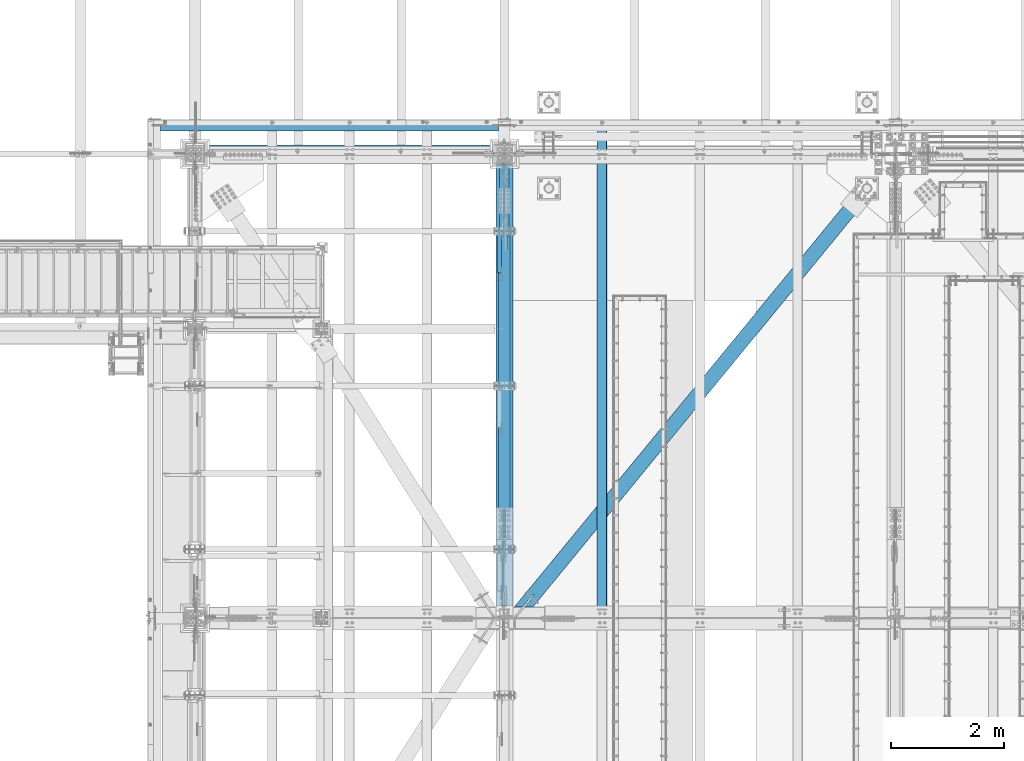
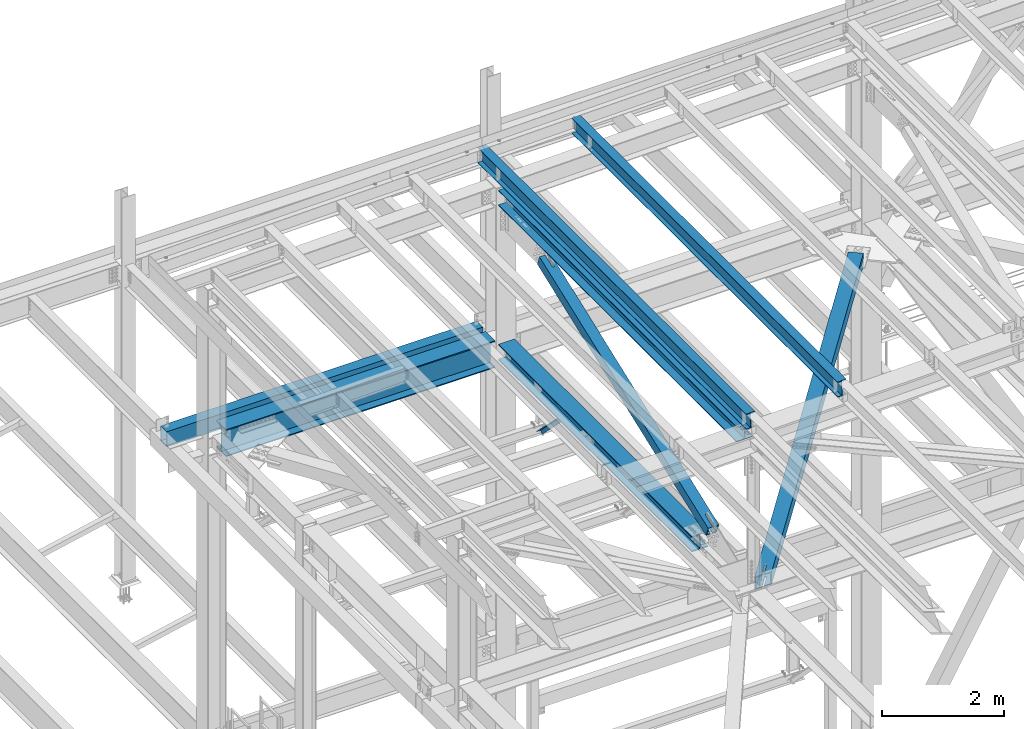
# One storey, part 1888 of 3843: 7 beams, 2 members, 9 elements without a shape of their own.
"""IFC2X3 building model written with IfcOpenShell, lengths in millimetres."""

from ifc_helpers import new_model, si_unit, frame, origin_with_axes, place, context, subcontext, project, spatial, faceted_brep, material, type_object, element, aggregate, save


model = new_model("IFC2X3")

# Units and contexts
model_context = context("Model", 3, precision=1e-05, world=origin_with_axes())
body_context = subcontext(model_context, "Body", "Model", "MODEL_VIEW")
ifc_project = project(units=[si_unit("LENGTHUNIT", "METRE", prefix="MILLI"), si_unit("AREAUNIT", "SQUARE_METRE"), si_unit("VOLUMEUNIT", "CUBIC_METRE"), si_unit("MASSUNIT", "GRAM", prefix="KILO"), si_unit("TIMEUNIT", "SECOND"), si_unit("PLANEANGLEUNIT", "RADIAN"), si_unit("SOLIDANGLEUNIT", "STERADIAN"), si_unit("THERMODYNAMICTEMPERATUREUNIT", "DEGREE_CELSIUS"), si_unit("LUMINOUSINTENSITYUNIT", "LUMEN")], contexts=[model_context])

# Site, building, storey
site_placement = place(None, origin_with_axes())
site = spatial("IfcSite", under=ifc_project, at=site_placement, CompositionType="ELEMENT")
building_placement = place(site_placement, origin_with_axes())
building = spatial("IfcBuilding", under=site, at=building_placement, Name="Undefined", CompositionType="ELEMENT")
storey_placement = place(building_placement, origin_with_axes())
storey = spatial("IfcBuildingStorey", under=building, at=storey_placement, Name="Undefined", CompositionType="ELEMENT", Elevation=0.0)

# Assembly, beam
assembly_1_placement = place(storey_placement, origin_with_axes())
assembly_1 = element("IfcElementAssembly", 1, at=assembly_1_placement, inside=storey, Name="BEAM", AssemblyPlace="NOTDEFINED", PredefinedType="RIGID_FRAME")
ifc_material_1 = material(Name="STEEL/A992")
beam_type_1 = type_object("IfcBeamType", Name="W12X26", PredefinedType="NOTDEFINED")
beam_1_placement = place(assembly_1_placement, frame((43792.6592623349, 83985.1612976655, 45730.1499365069), z_axis=(-0.0211520976501051, 0.00039400699987891, 0.999776191716668), x_axis=(0.0, 0.999999922344562, -0.000394095000135883)))
beam_1 = element("IfcBeam", 2, at=beam_1_placement, type_object=beam_type_1, material=ifc_material_1, Name="BEAM", ObjectType="W12X26", context=body_context, shape_type="Brep", body=[
    faceted_brep([(8748.71387345975, -3.17500000048312, -146.049999975585), (8748.71387345977, -82.5500000003376, -146.049999975723), (8748.71387345986, -82.5500000003449, -155.574999975746), (8748.71387345986, 82.5499999993408, -155.574999975448), (8748.71387345977, 82.5499999993335, -146.049999975425), (8748.71387345977, 3.17499999948632, -146.04999997557), (8748.71387346018, 3.17499999949359, -142.874999321568), (8748.71387346015, -3.17500000049768, -142.874999321597), (8749.68060338277, 3.17499999949359, -138.014919803456), (8749.68060338275, -3.17500000049768, -138.014919803478), (8752.4336172833, 3.17499999949359, -133.89474333523), (8752.43361728328, -3.17500000050495, -133.894743335251), (8756.55379375159, 3.17499999949359, -131.141729434697), (8756.55379375156, -3.17500000050495, -131.141729434727), (8761.41387326975, 3.17499999949359, -130.174999512106), (8761.41387326973, -3.17500000050495, -130.174999512128), (8818.55315012705, -3.17500000049768, -130.174999512412), (8818.55320306026, 3.17499999949359, -130.174999512412), (12.5811850809841, 3.17499999997381, 146.050000000287), (12.5818467461504, 82.549999999821, 146.050000000425), (8748.71387345965, 82.5499999992971, 146.050000025061), (8748.71387345964, 3.17499999944994, 146.050000024916), (12.699343723325, -82.5500000003594, -155.575000000019), (12.6955598859931, -82.549999999821, -146.050000000367), (12.6961738177852, -3.17499999995925, -146.05000000049), (12.5811321477668, -3.17500000001019, 146.050000000272), (12.5804704826005, -82.5499999998574, 146.050000000127), (12.5767175672809, -82.5499999998501, 155.575000000143), (12.5780938308308, 82.549999999821, 155.575000000448), (12.6962744843622, 3.17500000001019, -146.050000000199), (12.6968955877383, 82.5499999998865, -146.050000000643), (12.700657964604, 82.5499999993335, -155.575000000419), (8748.71387345965, -3.17500000052678, 146.050000024901), (8748.71387345965, -82.550000000374, 146.050000024756), (8748.7138734597, -82.550000000374, 155.575000024772), (8748.7138734597, 82.5499999992971, 155.57500002507), (8748.71387345999, -3.17500000053406, 142.875000297521), (8748.71387346002, 3.17499999945721, 142.875000297543), (8749.68060338256, -3.17500000053406, 138.014920779446), (8749.68060338259, 3.17499999944994, 138.014920779468), (8752.43361728308, -3.17500000053406, 133.894744311248), (8752.4336172831, 3.17499999945721, 133.894744311285), (8756.55379375129, -3.17500000052678, 131.141730410745), (8756.55379375131, 3.17499999945721, 131.141730410774), (8761.41387326943, -3.17500000052678, 130.175000488147), (8761.41387326944, 3.17499999945721, 130.175000488161), (8818.45057044142, -3.17500000052678, 130.175000487565), (8818.45062337464, 3.17499999944994, 130.175000487558), (8818.54648030871, 3.17499999947904, -113.112475336362), (8818.45562233418, 3.17499999944994, 117.487506764461)], [[[0, 1, 2, 3, 4, 5, 6, 7]], [[7, 6, 8, 9]], [[9, 8, 10, 11]], [[11, 10, 12, 13]], [[13, 12, 14, 15]], [[16, 15, 14, 17]], [[18, 19, 20, 21]], [[22, 23, 24, 25, 26, 27, 28, 19, 18, 29, 30, 31]], [[26, 25, 32, 33]], [[27, 26, 33, 34]], [[28, 27, 34, 35]], [[19, 28, 35, 20]], [[34, 33, 32, 36, 37, 21, 20, 35]], [[38, 39, 37, 36]], [[40, 41, 39, 38]], [[42, 43, 41, 40]], [[44, 45, 43, 42]], [[46, 47, 45, 44]], [[48, 49, 47, 46, 16, 17]], [[12, 10, 8, 6, 5, 29, 18, 21, 37, 39, 41, 43, 45, 47, 49, 48, 17, 14]], [[30, 29, 5, 4]], [[31, 30, 4, 3]], [[22, 31, 3, 2]], [[23, 22, 2, 1]], [[24, 23, 1, 0]], [[46, 44, 42, 40, 38, 36, 32, 25, 24, 0, 7, 9, 11, 13, 15, 16]]]),
])
aggregate(assembly_1, [beam_1])

assembly_2_placement = place(storey_placement, origin_with_axes())
assembly_2 = element("IfcElementAssembly", 3, at=assembly_2_placement, inside=storey, Name="BEAM", AssemblyPlace="NOTDEFINED", PredefinedType="RIGID_FRAME")
beam_2_placement = place(assembly_2_placement, frame((42059.1092623669, 83985.1465797427, 45692.6371083062), z_axis=(-0.0211520979557754, 0.000299403999859351, 0.999776224516924), x_axis=(0.0, 0.999999955158559, -0.000299471000047185)))
beam_2 = element("IfcBeam", 4, at=beam_2_placement, type_object=beam_type_1, material=ifc_material_1, Name="BEAM", ObjectType="W12X26", context=body_context, shape_type="Brep", body=[
    faceted_brep([(12.7004890030294, 82.5499999993262, -155.574999999742), (12.6976716898789, 82.5500000003158, -146.050000000272), (8839.20039647813, 82.5500000005268, -146.050000010408), (8839.20039647816, 82.5500000005632, -155.575000010431), (12.6971688932244, 3.17500000047585, -146.050000000323), (8839.20039647768, 3.17500000068685, -146.050000010466), (12.6097129801346, 3.17499999950087, 146.050000000309), (8839.200396477, 3.17499999971187, 146.049999990166), (12.6102157767891, 82.5499999993408, 146.050000000359), (8839.20039647748, 82.5499999995591, 146.049999990209), (12.6073639535316, 82.5499999993117, 155.575000000375), (8839.20039647745, 82.5499999995227, 155.574999990233), (12.606318136488, -82.5500000003449, 155.575000000281), (8839.20039647649, -82.5500000001339, 155.574999990138), (12.6091699597309, -82.5500000003231, 146.050000000265), (8839.20039647652, -82.5500000001048, 146.049999990115), (12.6096727563854, -3.17500000048312, 146.050000000309), (8839.20039647697, -3.17500000027212, 146.049999990159), (12.6971286695043, -3.17499999950815, -146.050000000323), (8839.20039647765, -3.17499999929714, -146.050000010466), (12.6966258728353, -82.5499999993481, -146.050000000367), (8839.20039647717, -82.5499999991371, -146.050000010517), (12.6995121410655, -82.5500000004104, -155.574999999495), (8839.2003964772, -82.549999999108, -155.575000010533)], [[[0, 1, 2, 3]], [[1, 4, 5, 2]], [[4, 6, 7, 5]], [[6, 8, 9, 7]], [[8, 10, 11, 9]], [[10, 12, 13, 11]], [[12, 14, 15, 13]], [[14, 16, 17, 15]], [[16, 18, 19, 17]], [[18, 20, 21, 19]], [[20, 22, 23, 21]], [[22, 0, 3, 23]], [[5, 7, 9, 11, 13, 15, 17, 19, 21, 23, 3, 2]], [[22, 20, 18, 16, 14, 12, 10, 8, 6, 4, 1, 0]]]),
])
aggregate(assembly_2, [beam_2])

assembly_3_placement = place(storey_placement, origin_with_axes())
assembly_3 = element("IfcElementAssembly", 5, at=assembly_3_placement, inside=storey, Name="BEAM", AssemblyPlace="NOTDEFINED", PredefinedType="RIGID_FRAME")
beam_type_2 = type_object("IfcBeamType", Name="W21X101", PredefinedType="NOTDEFINED")
beam_3_placement = place(assembly_3_placement, frame((36576.0, 92214.7, 42197.3375), z_axis=(0.0, 0.0, 1.0), x_axis=(1.0, 0.0, 0.0)))
beam_3 = element("IfcBeam", 6, at=beam_3_placement, type_object=beam_type_2, material=ifc_material_1, Name="BEAM", ObjectType="W21X101", context=body_context, shape_type="Brep", body=[
    faceted_brep([(190.5, -155.575000000001, -271.462500000001), (190.5, 155.575000000001, -271.462500000001), (5289.55, 155.575000000001, -271.462500000001), (5289.55, -155.575000000001, -271.462500000001), (190.5, -155.575000000001, -250.824999999997), (190.5, -6.34999999999854, -250.824999999997), (190.5, -6.34999999999854, 250.824999999997), (190.5, -155.575000000001, 250.824999999997), (190.5, -155.575000000001, 271.462500000001), (190.5, 155.575000000001, 271.462500000001), (190.5, 155.575000000001, 250.824999999997), (190.5, 6.34999999999854, 250.824999999997), (190.5, 6.34999999999854, -250.824999999997), (190.5, 155.575000000001, -250.824999999997), (5289.55, -155.575000000001, -250.824999999997), (5289.55, -6.34999999999854, -250.824999999997), (5289.55, -6.34999999999854, 250.824999999997), (5289.55, -155.575000000001, 250.824999999997), (5289.55, -155.575000000001, 271.462500000001), (5289.55, 155.575000000001, 271.462500000001), (5289.55, 155.575000000001, 250.824999999997), (5289.55, 6.34999999999854, 250.824999999997), (5289.55, 6.34999999999854, -250.824999999997), (5289.55, 155.575000000001, -250.824999999997)], [[[0, 1, 2, 3]], [[0, 4, 5, 6, 7, 8, 9, 10, 11, 12, 13, 1]], [[5, 4, 14, 15]], [[6, 5, 15, 16]], [[7, 6, 16, 17]], [[8, 7, 17, 18]], [[9, 8, 18, 19]], [[10, 9, 19, 20]], [[11, 10, 20, 21]], [[12, 11, 21, 22]], [[13, 12, 22, 23]], [[1, 13, 23, 2]], [[22, 21, 20, 19, 18, 17, 16, 15, 14, 3, 2, 23]], [[4, 0, 3, 14]]]),
])
aggregate(assembly_3, [beam_3])

assembly_4_placement = place(storey_placement, origin_with_axes())
assembly_4 = element("IfcElementAssembly", 7, at=assembly_4_placement, inside=storey, Name="GIRT", AssemblyPlace="NOTDEFINED", PredefinedType="RIGID_FRAME")
ifc_material_2 = material()
beam_type_3 = type_object("IfcBeamType", Name="HSS12X8X3/8", PredefinedType="NOTDEFINED")
beam_4_placement = place(assembly_4_placement, frame((35963.225, 92722.7, 42214.8), z_axis=(0.0, 0.0, 1.0), x_axis=(1.0, 0.0, 0.0)))
beam_4 = element("IfcBeam", 8, at=beam_4_placement, type_object=beam_type_3, material=ifc_material_2, Name="GIRT", ObjectType="HSS12X8X3/8", context=body_context, shape_type="Brep", body=[
    faceted_brep([(5995.9875, 101.599999999999, -152.400000000001), (5995.9875, -101.599999999999, -152.400000000001), (1.58750000000146, -101.599999999999, -152.400000000001), (1.58750000000146, 101.599999999999, -152.400000000001), (5995.9875, 101.599999999999, 152.400000000001), (1.58750000000146, 101.599999999999, 152.400000000001), (5995.9875, -101.599999999999, 152.400000000001), (1.58750000000146, -101.599999999999, 152.400000000001), (5995.9875, 92.0750000000007, -142.875), (5995.9875, -92.0750000000007, -142.875), (5995.9875, -92.0750000000007, 142.875), (5995.9875, 92.0750000000007, 142.875), (1.58750000000146, -92.0750000000007, 142.875), (1.58750000000146, 92.0750000000007, 142.875), (1.58750000000146, 92.0750000000007, -142.875), (1.58750000000146, -92.0750000000007, -142.875)], [[[0, 1, 2, 3]], [[4, 0, 3, 5]], [[6, 4, 5, 7]], [[1, 6, 7, 2]], [[0, 4, 6, 1], [8, 9, 10, 11]], [[11, 10, 12, 13]], [[8, 11, 13, 14]], [[9, 8, 14, 15]], [[10, 9, 15, 12]], [[3, 2, 7, 5], [14, 13, 12, 15]]]),
])
aggregate(assembly_4, [beam_4])

# Assembly, member
assembly_5_placement = place(storey_placement, origin_with_axes())
assembly_5 = element("IfcElementAssembly", 9, at=assembly_5_placement, inside=storey, Name="ANGLE", AssemblyPlace="NOTDEFINED", PredefinedType="RIGID_FRAME")
ifc_material_3 = material(Name="STEEL/A572-50")
member_type_1 = type_object("IfcMemberType", Name="L3X3X1/4", PredefinedType="NOTDEFINED")
member_1_placement = place(assembly_5_placement, frame((41973.5, 89889.8478294408, 42253.6521705007), z_axis=(0.0, -0.707106781186548, -0.707106781186548), x_axis=(5.70000238222118e-08, 0.707106781186546, -0.707106781186546)))
member_1 = element("IfcMember", 10, at=member_1_placement, type_object=member_type_1, material=ifc_material_3, Name="ANGLE", ObjectType="L3X3X1/4", context=body_context, shape_type="Brep", body=[
    faceted_brep([(1265.10086725769, -38.0999999999985, -31.7499999999272), (1265.10086725772, -38.0999999999985, -38.0999999999112), (1265.10086725772, 38.0999999999985, -38.0999999999112), (1265.10086725733, 38.0999999999985, 38.099999999904), (1265.10086725733, 31.75, 38.099999999904), (1265.10086725769, 31.75, -31.7499999999272), (274.500867262255, 31.75, 38.0999999999112), (274.500867262619, 31.75, -31.7499999999272), (274.500867262619, -38.0999999999985, -31.7499999999272), (274.500867262648, -38.0999999999985, -38.0999999999112), (274.500867262648, 38.0999999999985, -38.0999999999112), (274.500867262255, 38.0999999999985, 38.0999999999112)], [[[0, 1, 2, 3, 4, 5]], [[5, 4, 6, 7]], [[0, 5, 7, 8]], [[1, 0, 8, 9]], [[2, 1, 9, 10]], [[3, 2, 10, 11]], [[4, 3, 11, 6]], [[10, 9, 8, 7, 6, 11]]]),
])
aggregate(assembly_5, [member_1])

# Assembly, beam
assembly_6_placement = place(storey_placement, origin_with_axes())
assembly_6 = element("IfcElementAssembly", 11, at=assembly_6_placement, inside=storey, Name="BEAM", AssemblyPlace="NOTDEFINED", PredefinedType="RIGID_FRAME")
beam_type_4 = type_object("IfcBeamType", Name="W12X79", PredefinedType="NOTDEFINED")
beam_5_placement = place(assembly_6_placement, frame((42062.4, 85661.5000000582, 42248.6579913964), z_axis=(0.0, 0.000321673000085866, 0.999999948263239), x_axis=(0.0, 0.999999948263239, -0.000321673000078448)))
beam_5 = element("IfcBeam", 12, at=beam_5_placement, type_object=beam_type_4, material=ifc_material_1, Name="BEAM", ObjectType="W12X79", context=body_context, shape_type="Brep", body=[
    faceted_brep([(6.34999999578577, -153.987500000003, -138.11249999961), (6.34999999578577, -153.987500000003, -157.162499999562), (6362.75088412264, -153.987500000003, -157.16249997681), (6362.74475625168, -153.987500000003, -138.112499976858), (6.34999999578577, -6.34999999999854, -138.11249999961), (6362.74475625168, -6.34999999999854, -138.112499976858), (6.34999999578577, -6.34999999999854, 138.112499999675), (6362.65590212263, -6.34999999999854, 138.112500022427), (6.34999999578577, -153.987500000003, 138.112499999675), (6362.65590212263, -153.987500000003, 138.112500022427), (6.34999999578577, -153.987500000003, 157.162499999627), (6362.64977425167, -153.987500000003, 157.162500022379), (6.34999999578577, 153.987500000003, 157.162499999627), (6362.64977425167, 153.987500000003, 157.162500022379), (6.34999999578577, 153.987500000003, 138.112499999675), (6362.65590212263, 153.987500000003, 138.112500022427), (6.34999999578577, 6.34999999999854, 138.112499999675), (6362.65590212263, 6.34999999999854, 138.112500022427), (6.34999999578577, 6.34999999999854, -138.11249999961), (6362.74475625168, 6.34999999999854, -138.112499976858), (6.34999999578577, 153.987500000003, -138.11249999961), (6362.74475625168, 153.987500000003, -138.112499976858), (6.34999999578577, 153.987500000003, -157.162499999562), (6362.75088412264, 153.987500000003, -157.16249997681)], [[[0, 1, 2, 3]], [[4, 0, 3, 5]], [[6, 4, 5, 7]], [[8, 6, 7, 9]], [[10, 8, 9, 11]], [[12, 10, 11, 13]], [[14, 12, 13, 15]], [[16, 14, 15, 17]], [[18, 16, 17, 19]], [[20, 18, 19, 21]], [[1, 0, 4, 6, 8, 10, 12, 14, 16, 18, 20, 22]], [[1, 22, 23, 2]], [[19, 17, 15, 13, 11, 9, 7, 5, 3, 2, 23, 21]], [[22, 20, 21, 23]]]),
])
aggregate(assembly_6, [beam_5])

# Assembly, member
assembly_7_placement = place(storey_placement, origin_with_axes())
assembly_7 = element("IfcElementAssembly", 13, at=assembly_7_placement, inside=storey, AssemblyPlace="NOTDEFINED", PredefinedType="RIGID_FRAME")
member_type_2 = type_object("IfcMemberType", Name="HSS8X8X1/2", PredefinedType="NOTDEFINED")
member_2_placement = place(assembly_7_placement, frame((42062.4, 83985.1, 42249.1989165104), z_axis=(1.0, 0.0, 0.0), x_axis=(0.0, 0.936145725867102, 0.351612257950085)))
member_2 = element("IfcMember", 14, at=member_2_placement, type_object=member_type_2, material=ifc_material_2, ObjectType="HSS8X8X1/2", context=body_context, shape_type="Brep", body=[
    faceted_brep([(1357.61058050461, -101.599999994112, 17.4625000000015), (1357.6105805047, -88.8999999941625, 17.4625000000015), (1610.0230808741, -88.8999999931548, 17.4625000000015), (1610.02308087397, -101.599999993097, 17.4625000000015), (1616.70569016575, -88.8999999931293, 16.1332463655199), (1616.70569016565, -101.599999993075, 16.1332463655199), (1622.37093277075, -88.8999999931075, 12.3478522782025), (1622.37093277063, -101.599999993046, 12.3478522782025), (1626.15632685805, -88.8999999930966, 6.68260967316746), (1626.15632685793, -101.599999993032, 6.68260967316746), (1610.02308087397, -101.599999993097, -17.4625000000015), (1610.0230808741, -88.8999999931548, -17.4625000000015), (1357.6105805047, -88.8999999941625, -17.4625000000015), (1357.61058050461, -101.599999994112, -17.4625000000015), (1616.70569016565, -101.599999993075, -16.1332463655199), (1616.70569016575, -88.8999999931293, -16.1332463655199), (1622.37093277063, -101.599999993046, -12.3478522782025), (1622.37093277075, -88.8999999931075, -12.3478522782025), (1626.15632685793, -101.599999993032, -6.68260967316746), (1626.15632685805, -88.8999999930966, -6.68260967316746), (1627.4855804924, -101.599999993021, 3.81471181754023e-07), (1627.48558049253, -88.8999999930893, 3.81471181754023e-07), (1357.61058050592, 88.900000005011, 17.4625000000015), (1357.61058050599, 101.600000004953, 17.4625000000015), (1610.02308087594, 101.600000005961, 17.4625000000015), (1610.02308087582, 88.9000000060223, 17.4625000000015), (1616.7056901676, 101.60000000599, 16.1332463655199), (1616.70569016747, 88.9000000060478, 16.1332463655199), (1622.37093277258, 101.600000006012, 12.3478522782025), (1622.37093277246, 88.9000000060732, 12.3478522782025), (1626.15632685987, 101.600000006027, 6.68260967316746), (1626.15632685977, 88.9000000060805, 6.68260967316746), (1610.02308087582, 88.9000000060223, -17.4625000000015), (1610.02308087594, 101.600000005961, -17.4625000000015), (1357.61058050599, 101.600000004953, -17.4625000000015), (1357.61058050592, 88.900000005011, -17.4625000000015), (1616.70569016747, 88.9000000060478, -16.1332463655199), (1616.7056901676, 101.60000000599, -16.1332463655199), (1622.37093277246, 88.9000000060732, -12.3478522782025), (1622.37093277258, 101.600000006012, -12.3478522782025), (1626.15632685977, 88.9000000060805, -6.68260967316746), (1626.15632685987, 101.600000006027, -6.68260967316746), (1627.48558049423, 88.9000000060878, 3.81471181754023e-07), (1627.48558049437, 101.600000006038, 3.81471181754023e-07), (1357.6105805047, -88.8999999941625, 88.9000000000015), (1357.61058050592, 88.900000005011, 88.9000000000015), (7279.42376524339, 88.9000000286615, 88.9000000000015), (7279.42376524217, -88.8999999705084, 88.9000000000015), (1357.61058050599, 101.600000004953, 101.599999999999), (7279.42376524347, 101.600000028611, 101.599999999999), (7279.42376524347, 101.600000028611, 41.2750000000015), (7027.01126488511, 101.6000000276, 41.2750000000015), (7020.32865559346, 101.600000027571, 39.9457463655199), (7014.66341298845, 101.600000027545, 36.1603522782025), (7010.87801890117, 101.600000027531, 30.4951096731675), (7009.54876526671, 101.600000027527, 23.8125003814712), (7010.87801890117, 101.600000027531, 17.1298903268325), (7014.66341298845, 101.600000027545, 11.4646477217975), (7020.32865559346, 101.600000027571, 7.67925363448012), (7027.01126488511, 101.6000000276, 6.34999999999854), (7279.42376524347, 101.600000028611, 6.34999999999854), (7279.42376524347, 101.600000028611, -101.599999999999), (1357.61058050599, 101.600000004953, -101.599999999999), (7279.42376524339, 88.9000000286615, 41.2750000000015), (7027.01126488499, 88.9000000276537, 41.2750000000015), (7020.32865559334, 88.9000000276246, 39.9457463655199), (7014.66341298835, 88.9000000276064, 36.1603522782025), (7010.87801890104, 88.9000000275919, 30.4951096731675), (7009.54876526658, 88.9000000275882, 23.8125003814712), (7010.87801890104, 88.9000000275919, 17.1298903268325), (7014.66341298835, 88.9000000276064, 11.4646477217975), (7020.32865559334, 88.9000000276246, 7.67925363448012), (7027.01126488499, 88.9000000276537, 6.34999999999854), (7279.42376524339, 88.9000000286615, 6.34999999999854), (1357.61058050592, 88.900000005011, -88.9000000000015), (1357.6105805047, -88.8999999941625, -88.9000000000015), (7279.42376524217, -88.8999999705084, -88.9000000000015), (7279.42376524339, 88.9000000286615, -88.9000000000015), (7020.32865559151, -101.59999997148, 39.9457463655199), (7020.32865559163, -88.8999999715488, 39.9457463655199), (7027.01126488329, -88.8999999715161, 41.2750000000015), (7027.01126488316, -101.599999971459, 41.2750000000015), (7014.66341298651, -101.599999971506, 36.1603522782025), (7014.66341298663, -88.899999971567, 36.1603522782025), (7010.87801889921, -101.599999971535, 30.4951096731675), (7010.87801889933, -88.8999999715816, 30.4951096731675), (7009.54876526474, -101.599999971528, 23.8125003814712), (7009.54876526486, -88.8999999715925, 23.8125003814712), (7010.87801889921, -101.599999971535, 17.1298903268325), (7010.87801889933, -88.8999999715816, 17.1298903268325), (7014.66341298651, -101.599999971506, 11.4646477217975), (7014.66341298663, -88.899999971567, 11.4646477217975), (7020.32865559151, -101.59999997148, 7.67925363448012), (7020.32865559163, -88.8999999715488, 7.67925363448012), (7027.01126488316, -101.599999971459, 6.34999999999854), (7027.01126488329, -88.8999999715161, 6.34999999999854), (7279.42376524209, -101.599999970455, 6.34999999999854), (7279.42376524217, -88.8999999705084, 6.34999999999854), (7279.42376524209, -101.599999970455, -101.599999999999), (1357.61058050461, -101.599999994112, -101.599999999999), (7279.42376524217, -88.8999999705084, 41.2750000000015), (7279.42376524209, -101.599999970455, 41.2750000000015), (7279.42376524209, -101.599999970455, 101.599999999999), (1357.61058050461, -101.599999994112, 101.599999999999)], [[[0, 1, 2, 3]], [[3, 2, 4, 5]], [[5, 4, 6, 7]], [[7, 6, 8, 9]], [[10, 11, 12, 13]], [[14, 15, 11, 10]], [[16, 17, 15, 14]], [[18, 19, 17, 16]], [[20, 21, 19, 18]], [[9, 8, 21, 20]], [[22, 23, 24, 25]], [[25, 24, 26, 27]], [[27, 26, 28, 29]], [[29, 28, 30, 31]], [[32, 33, 34, 35]], [[36, 37, 33, 32]], [[38, 39, 37, 36]], [[40, 41, 39, 38]], [[42, 43, 41, 40]], [[31, 30, 43, 42]], [[44, 45, 46, 47]], [[28, 26, 24, 23, 48, 49, 50, 51, 52, 53, 54, 55, 56, 57, 58, 59, 60, 61, 62, 34, 33, 37, 39, 41, 43, 30]], [[63, 64, 51, 50]], [[65, 52, 51, 64]], [[66, 53, 52, 65]], [[67, 54, 53, 66]], [[68, 55, 54, 67]], [[69, 56, 55, 68]], [[70, 57, 56, 69]], [[71, 58, 57, 70]], [[72, 59, 58, 71]], [[73, 60, 59, 72]], [[74, 75, 76, 77]], [[78, 79, 80, 81]], [[82, 83, 79, 78]], [[84, 85, 83, 82]], [[86, 87, 85, 84]], [[88, 89, 87, 86]], [[90, 91, 89, 88]], [[92, 93, 91, 90]], [[94, 95, 93, 92]], [[96, 97, 95, 94]], [[98, 61, 60, 73, 77, 76, 97, 96]], [[99, 62, 61, 98]], [[75, 74, 35, 34, 62, 99, 13, 12]], [[6, 4, 2, 1, 44, 47, 100, 80, 79, 83, 85, 87, 89, 91, 93, 95, 97, 76, 75, 12, 11, 15, 17, 19, 21, 8]], [[101, 81, 80, 100]], [[47, 46, 63, 50, 49, 102, 101, 100]], [[48, 103, 102, 49]], [[16, 14, 10, 13, 99, 98, 96, 94, 92, 90, 88, 86, 84, 82, 78, 81, 101, 102, 103, 0, 3, 5, 7, 9, 20, 18]], [[103, 48, 23, 22, 45, 44, 1, 0]], [[38, 36, 32, 35, 74, 77, 73, 72, 71, 70, 69, 68, 67, 66, 65, 64, 63, 46, 45, 22, 25, 27, 29, 31, 42, 40]]]),
])
aggregate(assembly_7, [member_2])

# Assembly, beam
assembly_8_placement = place(storey_placement, origin_with_axes())
assembly_8 = element("IfcElementAssembly", 15, at=assembly_8_placement, inside=storey, AssemblyPlace="NOTDEFINED", PredefinedType="RIGID_FRAME")
beam_type_5 = type_object("IfcBeamType", Name="HSS10X10X3/4", PredefinedType="NOTDEFINED")
beam_6_placement = place(assembly_8_placement, frame((42240.2, 83985.1, 42246.55), z_axis=(0.772893373971288, -0.634535918976442, 0.0), x_axis=(0.634535918976437, 0.772893373971293, 0.0)))
beam_6 = element("IfcBeam", 16, at=beam_6_placement, type_object=beam_type_5, material=ifc_material_2, ObjectType="HSS10X10X3/4", context=body_context, shape_type="Brep", body=[
    faceted_brep([(9595.05957983305, 26.9874999999956, 127.000000028405), (9342.64708020692, 26.9874999999956, 127.000000027656), (9342.64708020676, 26.9874999999956, 107.950000027704), (9595.05957983293, 26.9874999999956, 107.950000028461), (9337.179490521, 25.8999287917104, 127.000000027634), (9337.17949052084, 25.8999287917104, 107.950000027689), (9332.54429180092, 22.8027880244699, 127.00000002762), (9332.54429180076, 22.8027880244699, 107.950000027682), (9329.44715103366, 18.167589304423, 127.00000002762), (9329.44715103351, 18.167589304423, 107.950000027668), (9328.35957982538, 12.6999996185259, 127.000000027605), (9328.35957982522, 12.6999996185259, 107.950000027668), (9329.44715103366, 7.23241069557116, 127.00000002762), (9329.44715103351, 7.23241069557116, 107.950000027668), (9332.54429180092, 2.59721197552426, 127.00000002762), (9332.54429180076, 2.59721197552426, 107.950000027682), (9337.179490521, -0.499928791716229, 127.000000027634), (9337.17949052084, -0.499928791716229, 107.950000027689), (9342.64708020692, -1.58750000000146, 127.000000027656), (9342.64708020676, -1.58750000000146, 107.950000027704), (9595.05957983305, -1.58750000000146, 127.000000028405), (9595.05957983293, -1.58750000000146, 107.950000028461), (9595.05957983171, 26.9874999999956, -107.949999970944), (9342.647080205, 26.9874999999956, -107.949999971708), (9342.64708020483, 26.9874999999956, -126.99999997166), (9595.05957983161, 26.9874999999956, -126.999999970911), (9337.17949051905, 25.8999287917104, -107.949999971723), (9337.1794905189, 25.8999287917104, -126.999999971675), (9332.54429179899, 22.8027880244699, -107.949999971745), (9332.54429179883, 22.8027880244699, -126.999999971689), (9329.44715103172, 18.167589304423, -107.949999971752), (9329.44715103156, 18.167589304423, -126.999999971689), (9328.35957982343, 12.6999996185259, -107.949999971759), (9328.35957982329, 12.6999996185259, -126.999999971711), (9329.44715103172, 7.23241069557116, -107.949999971752), (9329.44715103156, 7.23241069557116, -126.999999971689), (9332.54429179899, 2.59721197552426, -107.949999971745), (9332.54429179883, 2.59721197552426, -126.999999971689), (9337.17949051905, -0.499928791716229, -107.949999971723), (9337.1794905189, -0.499928791716229, -126.999999971675), (9342.647080205, -1.58750000000146, -107.949999971708), (9342.64708020483, -1.58750000000146, -126.99999997166), (9595.05957983171, -1.58750000000146, -107.949999970944), (9595.05957983161, -1.58750000000146, -126.999999970911), (520.888642611997, 107.949999999997, 14.2875006717732), (520.888642611997, 127.0, 14.2875006717732), (526.35623229884, 127.0, 13.1999294678753), (526.35623229884, 107.949999999997, 13.1999294678753), (530.991431021416, 127.0, 10.1027887042655), (530.991431021416, 107.949999999997, 10.1027887042655), (534.088571792345, 127.0, 5.46758998659789), (534.088571792345, 107.949999999997, 5.46758998659789), (535.176143004898, 127.0, 1.06545485323295e-06), (535.176143004898, 107.949999999997, 1.06545485323295e-06), (534.088571800913, 127.0, -5.46758862111892), (534.088571800913, 107.949999999997, -5.46758862111892), (530.991431037416, 127.0, -10.1027873434723), (530.991431037416, 107.949999999997, -10.1027873434723), (526.356232319988, 127.0, -13.1999281143289), (526.356232319988, 107.949999999997, -13.1999281143289), (520.888642635131, 127.0, -14.287499326987), (520.888642635131, 107.949999999997, -14.287499326987), (245.016420763346, 127.0, -14.2874995510356), (245.016420763346, 107.949999999997, -14.2874995510356), (9595.05957915825, 107.949999999997, -107.950000001394), (168.12066424172, 107.949999999997, -107.949999999568), (168.12066424172, -107.949999999997, -107.949999999568), (9595.05957915825, -107.949999999997, -107.950000001394), (9595.05957915825, -107.949999999997, 107.949999997647), (245.016420763346, -107.949999999997, -14.2874995510356), (520.888642635131, -107.949999999997, -14.287499326987), (526.356232319988, -107.949999999997, -13.1999281143289), (530.991431037416, -107.949999999997, -10.1027873434723), (534.088571800913, -107.949999999997, -5.46758862111892), (535.176143004898, -107.949999999997, 1.06545485323295e-06), (534.088571792345, -107.949999999997, 5.46758998659789), (530.991431021416, -107.949999999997, 10.1027887042655), (526.35623229884, -107.949999999997, 13.1999294678753), (520.888642611997, -107.949999999997, 14.2875006717732), (268.476142995274, -107.949999999997, 14.2875004680172), (345.371898763963, -107.949999999997, 107.949999999437), (345.371898763963, 107.949999999997, 107.949999999437), (9595.05957915825, 107.949999999997, 107.949999997647), (268.476142995274, 107.949999999997, 14.2875004680172), (268.476142995274, 127.0, 14.2875004680172), (9595.05957915825, 127.0, 126.999999997548), (9595.05957915825, 127.0, -127.000000001302), (152.480849430937, 127.0, -126.999999999469), (361.011713574746, 127.0, 126.999999999352), (9595.05957915825, -127.0, -127.000000001302), (152.480849430937, -127.0, -126.999999999469), (245.016420763346, -127.0, -14.2874995510356), (520.888642635131, -127.0, -14.287499326987), (526.356232319988, -127.0, -13.1999281143289), (530.991431037416, -127.0, -10.1027873434723), (534.088571800913, -127.0, -5.46758862111892), (535.176143004898, -127.0, 1.06545485323295e-06), (534.088571792345, -127.0, 5.46758998659789), (530.991431021416, -127.0, 10.1027887042655), (526.35623229884, -127.0, 13.1999294678753), (520.888642611997, -127.0, 14.2875006717732), (268.476142995274, -127.0, 14.2875004680172), (361.011713574746, -127.0, 126.999999999352), (9595.05957915825, -127.0, 126.999999997548)], [[[0, 1, 2, 3]], [[4, 5, 2, 1]], [[6, 7, 5, 4]], [[8, 9, 7, 6]], [[10, 11, 9, 8]], [[12, 13, 11, 10]], [[14, 15, 13, 12]], [[16, 17, 15, 14]], [[18, 19, 17, 16]], [[20, 21, 19, 18]], [[22, 23, 24, 25]], [[26, 27, 24, 23]], [[28, 29, 27, 26]], [[30, 31, 29, 28]], [[32, 33, 31, 30]], [[34, 35, 33, 32]], [[36, 37, 35, 34]], [[38, 39, 37, 36]], [[40, 41, 39, 38]], [[42, 43, 41, 40]], [[44, 45, 46, 47]], [[47, 46, 48, 49]], [[49, 48, 50, 51]], [[51, 50, 52, 53]], [[53, 52, 54, 55]], [[55, 54, 56, 57]], [[57, 56, 58, 59]], [[59, 58, 60, 61]], [[61, 60, 62, 63]], [[38, 36, 34, 32, 30, 28, 26, 23, 22, 64, 65, 66, 67, 42, 40]], [[68, 67, 66, 69, 70, 71, 72, 73, 74, 75, 76, 77, 78, 79, 80]], [[68, 80, 81, 82, 3, 2, 5, 7, 9, 11, 13, 15, 17, 19, 21]], [[44, 47, 49, 51, 53, 55, 57, 59, 61, 63, 65, 64, 82, 81, 83]], [[45, 44, 83, 84]], [[85, 86, 87, 62, 60, 58, 56, 54, 52, 50, 48, 46, 45, 84, 88]], [[82, 64, 22, 25, 86, 85, 0, 3]], [[89, 90, 87, 86, 25, 24, 27, 29, 31, 33, 35, 37, 39, 41, 43]], [[66, 65, 63, 62, 87, 90, 91, 69]], [[92, 70, 69, 91]], [[93, 71, 70, 92]], [[94, 72, 71, 93]], [[95, 73, 72, 94]], [[96, 74, 73, 95]], [[97, 75, 74, 96]], [[98, 76, 75, 97]], [[99, 77, 76, 98]], [[100, 78, 77, 99]], [[78, 100, 101, 79]], [[84, 83, 81, 80, 79, 101, 102, 88]], [[100, 99, 98, 97, 96, 95, 94, 93, 92, 91, 90, 89, 103, 102, 101]], [[16, 14, 12, 10, 8, 6, 4, 1, 0, 85, 88, 102, 103, 20, 18]], [[103, 89, 43, 42, 67, 68, 21, 20]]]),
])
aggregate(assembly_8, [beam_6])

assembly_9_placement = place(storey_placement, origin_with_axes())
assembly_9 = element("IfcElementAssembly", 17, at=assembly_9_placement, inside=storey, Name="BEAM", AssemblyPlace="NOTDEFINED", PredefinedType="RIGID_FRAME")
beam_type_6 = type_object("IfcBeamType", Name="W12X65", PredefinedType="NOTDEFINED")
beam_7_placement = place(assembly_9_placement, frame((42062.4, 83985.0999998198, 45340.2008418066), z_axis=(0.0, 0.0, 1.0), x_axis=(0.0, 1.0, 0.0)))
beam_7 = element("IfcBeam", 18, at=beam_7_placement, type_object=beam_type_6, material=ifc_material_1, Name="BEAM", ObjectType="W12X65", context=body_context, shape_type="Brep", body=[
    faceted_brep([(212.725000000006, -152.399999999994, -138.112500000003), (212.725000000006, -152.399999999994, -153.987500000003), (8039.09999999887, -152.399999999994, -153.987500000003), (8039.09999999887, -152.399999999994, -138.112500000003), (212.725000000006, -4.76249999999709, -138.112500000003), (8039.09999999887, -4.76249999999709, -138.112500000003), (212.725000000006, -4.76249999999709, 138.112500000003), (8039.09999999887, -4.76249999999709, 138.112500000003), (212.725000000006, -152.399999999994, 138.112500000003), (8039.09999999887, -152.399999999994, 138.112500000003), (212.725000000006, -152.399999999994, 153.987500000003), (8039.09999999887, -152.399999999994, 153.987500000003), (212.725000000006, 152.399999999994, 153.987500000003), (8039.09999999887, 152.399999999994, 153.987500000003), (212.725000000006, 152.399999999994, 138.112500000003), (8039.09999999887, 152.399999999994, 138.112500000003), (212.725000000006, 4.76249999999709, 138.112500000003), (8039.09999999887, 4.76249999999709, 138.112500000003), (212.725000000006, 4.76249999999709, -138.112500000003), (8039.09999999887, 4.76249999999709, -138.112500000003), (212.725000000006, 152.399999999994, -138.112500000003), (8039.09999999887, 152.399999999994, -138.112500000003), (212.725000000006, 152.399999999994, -153.987500000003), (8039.09999999887, 152.399999999994, -153.987500000003)], [[[0, 1, 2, 3]], [[4, 0, 3, 5]], [[6, 4, 5, 7]], [[8, 6, 7, 9]], [[10, 8, 9, 11]], [[12, 10, 11, 13]], [[14, 12, 13, 15]], [[16, 14, 15, 17]], [[18, 16, 17, 19]], [[20, 18, 19, 21]], [[1, 0, 4, 6, 8, 10, 12, 14, 16, 18, 20, 22]], [[1, 22, 23, 2]], [[19, 17, 15, 13, 11, 9, 7, 5, 3, 2, 23, 21]], [[22, 20, 21, 23]]]),
])
aggregate(assembly_9, [beam_7])

save(model, "model.ifc")
